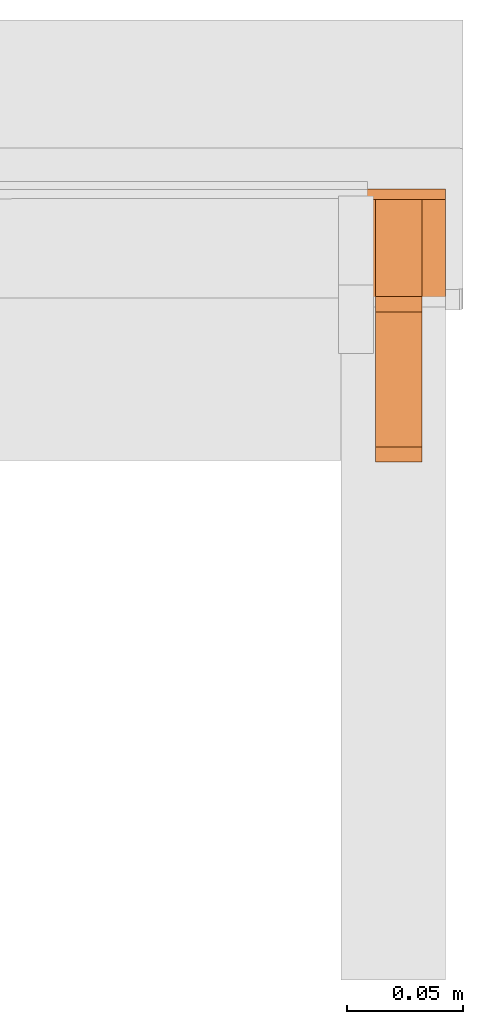
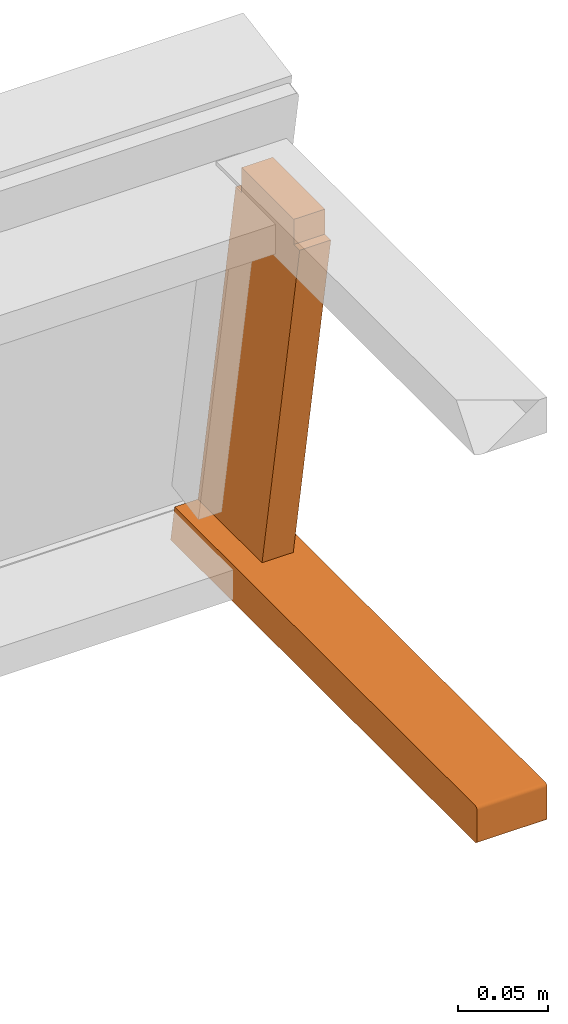
# One storey, part 4 of 5: 2 proxies, 1 element without a shape of its own.
"""IFC2X3 building model written with IfcOpenShell, lengths in metres."""

from ifc_helpers import new_model, si_unit, direction, origin_with_axes, place, context, project, spatial, faceted_brep, source, transform, mapped, element, aggregate, save


model = new_model("IFC2X3")

# Units and contexts
model_context = context("Model", 3, precision=1e-06, world=origin_with_axes(), true_north=direction((0.0, 1.0, 0.0)))
ifc_project = project(units=[si_unit("LENGTHUNIT", "METRE"), si_unit("AREAUNIT", "SQUARE_METRE"), si_unit("VOLUMEUNIT", "CUBIC_METRE")], contexts=[model_context])

# Site, building, storey
site_placement = place(None, origin_with_axes())
site = spatial("IfcSite", under=ifc_project, at=site_placement, CompositionType="ELEMENT")
building_placement = place(site_placement, origin_with_axes())
building = spatial("IfcBuilding", under=site, at=building_placement, Name="Default Building", CompositionType="ELEMENT")
storey_placement = place(building_placement, origin_with_axes())
storey = spatial("IfcBuildingStorey", under=building, at=storey_placement, Name="Default Storey", CompositionType="ELEMENT", Elevation=0.0)

# Assembly, proxies
assembly_placement = place(storey_placement, origin_with_axes())
assembly = element("IfcElementAssembly", 1, at=assembly_placement, inside=storey, Name="Pan H-68-037-A-REV reduced", ObjectType="Pan H-68-037-A-REV reduced", AssemblyPlace="NOTDEFINED", PredefinedType="NOTDEFINED")
shared_shape_1 = source(origin_with_axes(), model_context, "Body", "Brep", [
    faceted_brep([(0.2150000035762787, -0.08182960003614426, 0.24950098991394043), (0.2150000035762787, -0.07528966665267944, 0.24950098991394043), (0.19499999284744263, -0.08182960003614426, 0.24950098991394043), (0.19499999284744263, -0.08182960003614426, 0.24950098991394043), (0.2150000035762787, -0.07528966665267944, 0.24950098991394043), (0.19499999284744263, -0.07528966665267944, 0.24950098991394043), (0.2150000035762787, -0.07528966665267944, 0.24950098991394043), (0.2150000035762787, -0.07528966665267944, 0.26650097966194153), (0.19499999284744263, -0.07528966665267944, 0.24950098991394043), (0.19499999284744263, -0.07528966665267944, 0.24950098991394043), (0.2150000035762787, -0.07528966665267944, 0.26650097966194153), (0.19499999284744263, -0.07528966665267944, 0.26650097966194153), (0.2150000035762787, -0.07528966665267944, 0.26650097966194153), (0.2150000035762787, -0.07028967142105103, 0.26650097966194153), (0.19499999284744263, -0.07528966665267944, 0.26650097966194153), (0.19499999284744263, -0.07528966665267944, 0.26650097966194153), (0.2150000035762787, -0.07028967142105103, 0.26650097966194153), (0.19499999284744263, -0.07028967142105103, 0.26650097966194153), (0.2150000035762787, -0.07028967142105103, 0.26650097966194153), (0.2150000035762787, -0.022289669141173363, 0.26650097966194153), (0.19499999284744263, -0.07028967142105103, 0.26650097966194153), (0.19499999284744263, -0.07028967142105103, 0.26650097966194153), (0.2150000035762787, -0.022289669141173363, 0.26650097966194153), (0.19499999284744263, -0.022289669141173363, 0.26650097966194153), (0.2150000035762787, -0.022289669141173363, 0.26650097966194153), (0.2150000035762787, -0.017289668321609497, 0.26650097966194153), (0.19499999284744263, -0.022289669141173363, 0.26650097966194153), (0.19499999284744263, -0.022289669141173363, 0.26650097966194153), (0.2150000035762787, -0.017289668321609497, 0.26650097966194153), (0.19499999284744263, -0.017289668321609497, 0.26650097966194153), (0.2150000035762787, -0.017289668321609497, 0.26650097966194153), (0.2150000035762787, -0.017289668321609497, 0.24950098991394043), (0.19499999284744263, -0.017289668321609497, 0.26650097966194153), (0.19499999284744263, -0.017289668321609497, 0.26650097966194153), (0.2150000035762787, -0.017289668321609497, 0.24950098991394043), (0.19499999284744263, -0.017289668321609497, 0.24950098991394043), (0.2150000035762787, -0.017289668321609497, 0.24950098991394043), (0.2150000035762787, -0.010749737732112408, 0.24950098991394043), (0.19499999284744263, -0.017289668321609497, 0.24950098991394043), (0.19499999284744263, -0.017289668321609497, 0.24950098991394043), (0.2150000035762787, -0.010749737732112408, 0.24950098991394043), (0.19499999284744263, -0.010749737732112408, 0.24950098991394043), (0.2150000035762787, -0.010749737732112408, 0.24950098991394043), (0.2150000035762787, 0.031039930880069733, 0.012500000186264515), (0.19499999284744263, -0.010749737732112408, 0.24950098991394043), (0.19499999284744263, -0.010749737732112408, 0.24950098991394043), (0.2150000035762787, 0.031039930880069733, 0.012500000186264515), (0.19499999284744263, 0.031039930880069733, 0.012500000186264515), (0.2150000035762787, 0.031039930880069733, 0.012500000186264515), (0.2150000035762787, 0.02449999935925007, 0.012500000186264515), (0.19499999284744263, 0.031039930880069733, 0.012500000186264515), (0.19499999284744263, 0.031039930880069733, 0.012500000186264515), (0.2150000035762787, 0.02449999935925007, 0.012500000186264515), (0.19499999284744263, 0.02449999935925007, 0.012500000186264515), (0.2150000035762787, 0.02449999935925007, 0.012500000186264515), (0.2150000035762787, 0.02449999935925007, -0.0044999998062849045), (0.19499999284744263, 0.02449999935925007, 0.012500000186264515), (0.19499999284744263, 0.02449999935925007, 0.012500000186264515), (0.2150000035762787, 0.02449999935925007, -0.0044999998062849045), (0.19499999284744263, 0.02449999935925007, -0.0044999998062849045), (0.2150000035762787, 0.02449999935925007, -0.0044999998062849045), (0.2150000035762787, 0.019500000402331352, -0.0044999998062849045), (0.19499999284744263, 0.02449999935925007, -0.0044999998062849045), (0.19499999284744263, 0.02449999935925007, -0.0044999998062849045), (0.2150000035762787, 0.019500000402331352, -0.0044999998062849045), (0.19499999284744263, 0.019500000402331352, -0.0044999998062849045), (0.2150000035762787, 0.019500000402331352, -0.0044999998062849045), (0.2150000035762787, -0.02850000001490116, -0.0044999998062849045), (0.19499999284744263, 0.019500000402331352, -0.0044999998062849045), (0.19499999284744263, 0.019500000402331352, -0.0044999998062849045), (0.2150000035762787, -0.02850000001490116, -0.0044999998062849045), (0.19499999284744263, -0.02850000001490116, -0.0044999998062849045), (0.2150000035762787, -0.02850000001490116, -0.0044999998062849045), (0.2150000035762787, -0.03350000083446503, -0.0044999998062849045), (0.19499999284744263, -0.02850000001490116, -0.0044999998062849045), (0.19499999284744263, -0.02850000001490116, -0.0044999998062849045), (0.2150000035762787, -0.03350000083446503, -0.0044999998062849045), (0.19499999284744263, -0.03350000083446503, -0.0044999998062849045), (0.2150000035762787, -0.03350000083446503, -0.0044999998062849045), (0.2150000035762787, -0.03350000083446503, 0.012500000186264515), (0.19499999284744263, -0.03350000083446503, -0.0044999998062849045), (0.19499999284744263, -0.03350000083446503, -0.0044999998062849045), (0.2150000035762787, -0.03350000083446503, 0.012500000186264515), (0.19499999284744263, -0.03350000083446503, 0.012500000186264515), (0.2150000035762787, -0.03350000083446503, 0.012500000186264515), (0.2150000035762787, -0.04003993049263954, 0.012500000186264515), (0.19499999284744263, -0.03350000083446503, 0.012500000186264515), (0.19499999284744263, -0.03350000083446503, 0.012500000186264515), (0.2150000035762787, -0.04003993049263954, 0.012500000186264515), (0.19499999284744263, -0.04003993049263954, 0.012500000186264515), (0.2150000035762787, -0.04003993049263954, 0.012500000186264515), (0.2150000035762787, -0.08182960003614426, 0.24950098991394043), (0.19499999284744263, -0.04003993049263954, 0.012500000186264515), (0.19499999284744263, -0.04003993049263954, 0.012500000186264515), (0.2150000035762787, -0.08182960003614426, 0.24950098991394043), (0.19499999284744263, -0.08182960003614426, 0.24950098991394043), (0.2150000035762787, -0.07028967142105103, 0.26650097966194153), (0.2150000035762787, -0.07528966665267944, 0.26650097966194153), (0.2150000035762787, -0.07528966665267944, 0.24950098991394043), (0.2150000035762787, 0.02449999935925007, -0.0044999998062849045), (0.2150000035762787, 0.02449999935925007, 0.012500000186264515), (0.2150000035762787, 0.019500000402331352, -0.0044999998062849045), (0.2150000035762787, 0.019500000402331352, -0.0044999998062849045), (0.2150000035762787, 0.02449999935925007, 0.012500000186264515), (0.2150000035762787, -0.03350000083446503, 0.012500000186264515), (0.2150000035762787, 0.019500000402331352, -0.0044999998062849045), (0.2150000035762787, -0.03350000083446503, 0.012500000186264515), (0.2150000035762787, -0.02850000001490116, -0.0044999998062849045), (0.2150000035762787, -0.02850000001490116, -0.0044999998062849045), (0.2150000035762787, -0.03350000083446503, 0.012500000186264515), (0.2150000035762787, -0.03350000083446503, -0.0044999998062849045), (0.2150000035762787, -0.04003993049263954, 0.012500000186264515), (0.2150000035762787, -0.03350000083446503, 0.012500000186264515), (0.2150000035762787, -0.08182960003614426, 0.24950098991394043), (0.2150000035762787, -0.08182960003614426, 0.24950098991394043), (0.2150000035762787, -0.03350000083446503, 0.012500000186264515), (0.2150000035762787, 0.02449999935925007, 0.012500000186264515), (0.2150000035762787, -0.08182960003614426, 0.24950098991394043), (0.2150000035762787, 0.02449999935925007, 0.012500000186264515), (0.2150000035762787, -0.07528966665267944, 0.24950098991394043), (0.2150000035762787, -0.07528966665267944, 0.24950098991394043), (0.2150000035762787, 0.02449999935925007, 0.012500000186264515), (0.2150000035762787, 0.031039930880069733, 0.012500000186264515), (0.2150000035762787, -0.07528966665267944, 0.24950098991394043), (0.2150000035762787, 0.031039930880069733, 0.012500000186264515), (0.2150000035762787, -0.017289668321609497, 0.24950098991394043), (0.2150000035762787, -0.017289668321609497, 0.24950098991394043), (0.2150000035762787, 0.031039930880069733, 0.012500000186264515), (0.2150000035762787, -0.010749737732112408, 0.24950098991394043), (0.2150000035762787, -0.07028967142105103, 0.26650097966194153), (0.2150000035762787, -0.07528966665267944, 0.24950098991394043), (0.2150000035762787, -0.022289669141173363, 0.26650097966194153), (0.2150000035762787, -0.022289669141173363, 0.26650097966194153), (0.2150000035762787, -0.07528966665267944, 0.24950098991394043), (0.2150000035762787, -0.017289668321609497, 0.24950098991394043), (0.2150000035762787, -0.022289669141173363, 0.26650097966194153), (0.2150000035762787, -0.017289668321609497, 0.24950098991394043), (0.2150000035762787, -0.017289668321609497, 0.26650097966194153), (0.19499999284744263, -0.03350000083446503, 0.012500000186264515), (0.19499999284744263, -0.04003993049263954, 0.012500000186264515), (0.19499999284744263, -0.08182960003614426, 0.24950098991394043), (0.19499999284744263, -0.017289668321609497, 0.24950098991394043), (0.19499999284744263, -0.010749737732112408, 0.24950098991394043), (0.19499999284744263, 0.031039930880069733, 0.012500000186264515), (0.19499999284744263, -0.02850000001490116, -0.0044999998062849045), (0.19499999284744263, -0.03350000083446503, -0.0044999998062849045), (0.19499999284744263, -0.03350000083446503, 0.012500000186264515), (0.19499999284744263, -0.022289669141173363, 0.26650097966194153), (0.19499999284744263, -0.017289668321609497, 0.26650097966194153), (0.19499999284744263, -0.017289668321609497, 0.24950098991394043), (0.19499999284744263, -0.02850000001490116, -0.0044999998062849045), (0.19499999284744263, -0.03350000083446503, 0.012500000186264515), (0.19499999284744263, 0.019500000402331352, -0.0044999998062849045), (0.19499999284744263, 0.02449999935925007, 0.012500000186264515), (0.19499999284744263, 0.02449999935925007, -0.0044999998062849045), (0.19499999284744263, 0.019500000402331352, -0.0044999998062849045), (0.19499999284744263, -0.07528966665267944, 0.24950098991394043), (0.19499999284744263, -0.07528966665267944, 0.26650097966194153), (0.19499999284744263, -0.07028967142105103, 0.26650097966194153), (0.19499999284744263, 0.019500000402331352, -0.0044999998062849045), (0.19499999284744263, -0.03350000083446503, 0.012500000186264515), (0.19499999284744263, 0.02449999935925007, 0.012500000186264515), (0.19499999284744263, 0.02449999935925007, 0.012500000186264515), (0.19499999284744263, -0.03350000083446503, 0.012500000186264515), (0.19499999284744263, -0.08182960003614426, 0.24950098991394043), (0.19499999284744263, 0.02449999935925007, 0.012500000186264515), (0.19499999284744263, -0.08182960003614426, 0.24950098991394043), (0.19499999284744263, 0.031039930880069733, 0.012500000186264515), (0.19499999284744263, 0.031039930880069733, 0.012500000186264515), (0.19499999284744263, -0.08182960003614426, 0.24950098991394043), (0.19499999284744263, -0.07528966665267944, 0.24950098991394043), (0.19499999284744263, 0.031039930880069733, 0.012500000186264515), (0.19499999284744263, -0.07528966665267944, 0.24950098991394043), (0.19499999284744263, -0.017289668321609497, 0.24950098991394043), (0.19499999284744263, -0.017289668321609497, 0.24950098991394043), (0.19499999284744263, -0.07528966665267944, 0.24950098991394043), (0.19499999284744263, -0.07028967142105103, 0.26650097966194153), (0.19499999284744263, -0.017289668321609497, 0.24950098991394043), (0.19499999284744263, -0.07028967142105103, 0.26650097966194153), (0.19499999284744263, -0.022289669141173363, 0.26650097966194153)], [[[0, 1, 2]], [[3, 4, 5]], [[6, 7, 8]], [[9, 10, 11]], [[12, 13, 14]], [[15, 16, 17]], [[18, 19, 20]], [[21, 22, 23]], [[24, 25, 26]], [[27, 28, 29]], [[30, 31, 32]], [[33, 34, 35]], [[36, 37, 38]], [[39, 40, 41]], [[42, 43, 44]], [[45, 46, 47]], [[48, 49, 50]], [[51, 52, 53]], [[54, 55, 56]], [[57, 58, 59]], [[60, 61, 62]], [[63, 64, 65]], [[66, 67, 68]], [[69, 70, 71]], [[72, 73, 74]], [[75, 76, 77]], [[78, 79, 80]], [[81, 82, 83]], [[84, 85, 86]], [[87, 88, 89]], [[90, 91, 92]], [[93, 94, 95]], [[96, 97, 98]], [[99, 100, 101]], [[102, 103, 104]], [[105, 106, 107]], [[108, 109, 110]], [[111, 112, 113]], [[114, 115, 116]], [[117, 118, 119]], [[120, 121, 122]], [[123, 124, 125]], [[126, 127, 128]], [[129, 130, 131]], [[132, 133, 134]], [[135, 136, 137]], [[138, 139, 140]], [[141, 142, 143]], [[144, 145, 146]], [[147, 148, 149]], [[150, 151, 152]], [[153, 154, 155]], [[156, 157, 158]], [[159, 160, 161]], [[162, 163, 164]], [[165, 166, 167]], [[168, 169, 170]], [[171, 172, 173]], [[174, 175, 176]], [[177, 178, 179]]]),
])
proxy_1_placement = place(assembly_placement, origin_with_axes())
proxy_1 = element("IfcBuildingElementProxy", 2, at=proxy_1_placement, Name="24", ObjectType="24", CompositionType="ELEMENT", context=model_context, shape_type="MappedRepresentation", body=[
    mapped(shared_shape_1, transform((0.0, 0.0, 0.0), scale=1.0)),
])
shared_shape_2 = source(origin_with_axes(), model_context, "Body", "Brep", [
    faceted_brep([(0.22499999403953552, 0.031055916100740433, 0.012500000186264515), (0.22499999403953552, 0.03140857070684433, 0.010499999858438969), (0.18000000715255737, 0.031055916100740433, 0.012500000186264515), (0.18000000715255737, 0.031055916100740433, 0.012500000186264515), (0.22499999403953552, 0.03140857070684433, 0.010499999858438969), (0.18000000715255737, 0.03140857070684433, 0.010499999858438969), (0.22499999403953552, 0.03140857070684433, 0.010499999858438969), (0.22499999403953552, 0.0351114347577095, -0.010499999858438969), (0.18000000715255737, 0.03140857070684433, 0.010499999858438969), (0.18000000715255737, 0.03140857070684433, 0.010499999858438969), (0.22499999403953552, 0.0351114347577095, -0.010499999858438969), (0.18000000715255737, 0.0351114347577095, -0.010499999858438969), (0.22499999403953552, 0.0351114347577095, -0.010499999858438969), (0.22499999403953552, 0.0354640893638134, -0.012500000186264515), (0.18000000715255737, 0.0351114347577095, -0.010499999858438969), (0.18000000715255737, 0.0351114347577095, -0.010499999858438969), (0.22499999403953552, 0.0354640893638134, -0.012500000186264515), (0.18000000715255737, 0.0354640893638134, -0.012500000186264515), (0.22499999403953552, 0.0354640893638134, -0.012500000186264515), (0.22499999403953552, -0.04950062558054924, -0.012500000186264515), (0.18000000715255737, 0.0354640893638134, -0.012500000186264515), (0.18000000715255737, 0.0354640893638134, -0.012500000186264515), (0.22499999403953552, -0.04950062558054924, -0.012500000186264515), (0.18000000715255737, -0.04950062558054924, -0.012500000186264515), (0.22499999403953552, -0.04950062558054924, -0.012500000186264515), (0.22499999403953552, -0.30253592133522034, -0.012500000186264515), (0.18000000715255737, -0.04950062558054924, -0.012500000186264515), (0.18000000715255737, -0.04950062558054924, -0.012500000186264515), (0.22499999403953552, -0.30253592133522034, -0.012500000186264515), (0.18000000715255737, -0.30253592133522034, -0.012500000186264515), (0.22499999403953552, -0.3045358955860138, -0.010499999858438969), (0.18000000715255737, -0.3045358955860138, -0.010499999858438969), (0.18000000715255737, -0.3044677674770355, -0.011017638258635998), (0.22499999403953552, -0.3045358955860138, -0.010499999858438969), (0.18000000715255737, -0.3044677674770355, -0.011017638258635998), (0.22499999403953552, -0.3044677674770355, -0.011017638258635998), (0.22499999403953552, -0.3044677674770355, -0.011017638258635998), (0.18000000715255737, -0.3044677674770355, -0.011017638258635998), (0.18000000715255737, -0.3042679727077484, -0.011500000022351742), (0.22499999403953552, -0.3044677674770355, -0.011017638258635998), (0.18000000715255737, -0.3042679727077484, -0.011500000022351742), (0.22499999403953552, -0.3042679727077484, -0.011500000022351742), (0.22499999403953552, -0.3042679727077484, -0.011500000022351742), (0.18000000715255737, -0.3042679727077484, -0.011500000022351742), (0.18000000715255737, -0.30395013093948364, -0.011914213187992573), (0.22499999403953552, -0.3042679727077484, -0.011500000022351742), (0.18000000715255737, -0.30395013093948364, -0.011914213187992573), (0.22499999403953552, -0.30395013093948364, -0.011914213187992573), (0.22499999403953552, -0.30395013093948364, -0.011914213187992573), (0.18000000715255737, -0.30395013093948364, -0.011914213187992573), (0.18000000715255737, -0.30353590846061707, -0.012232051230967045), (0.22499999403953552, -0.30395013093948364, -0.011914213187992573), (0.18000000715255737, -0.30353590846061707, -0.012232051230967045), (0.22499999403953552, -0.30353590846061707, -0.012232051230967045), (0.22499999403953552, -0.30353590846061707, -0.012232051230967045), (0.18000000715255737, -0.30353590846061707, -0.012232051230967045), (0.18000000715255737, -0.3030535578727722, -0.012431851588189602), (0.22499999403953552, -0.30353590846061707, -0.012232051230967045), (0.18000000715255737, -0.3030535578727722, -0.012431851588189602), (0.22499999403953552, -0.3030535578727722, -0.012431851588189602), (0.22499999403953552, -0.3030535578727722, -0.012431851588189602), (0.18000000715255737, -0.3030535578727722, -0.012431851588189602), (0.18000000715255737, -0.30253592133522034, -0.012500000186264515), (0.22499999403953552, -0.3030535578727722, -0.012431851588189602), (0.18000000715255737, -0.30253592133522034, -0.012500000186264515), (0.22499999403953552, -0.30253592133522034, -0.012500000186264515), (0.22499999403953552, -0.3045358955860138, -0.010499999858438969), (0.22499999403953552, -0.3045358955860138, 0.010499999858438969), (0.18000000715255737, -0.3045358955860138, -0.010499999858438969), (0.18000000715255737, -0.3045358955860138, -0.010499999858438969), (0.22499999403953552, -0.3045358955860138, 0.010499999858438969), (0.18000000715255737, -0.3045358955860138, 0.010499999858438969), (0.22499999403953552, -0.30253592133522034, 0.012500000186264515), (0.18000000715255737, -0.30253592133522034, 0.012500000186264515), (0.18000000715255737, -0.3030535578727722, 0.012431851588189602), (0.22499999403953552, -0.30253592133522034, 0.012500000186264515), (0.18000000715255737, -0.3030535578727722, 0.012431851588189602), (0.22499999403953552, -0.3030535578727722, 0.012431851588189602), (0.22499999403953552, -0.3030535578727722, 0.012431851588189602), (0.18000000715255737, -0.3030535578727722, 0.012431851588189602), (0.18000000715255737, -0.30353590846061707, 0.012232051230967045), (0.22499999403953552, -0.3030535578727722, 0.012431851588189602), (0.18000000715255737, -0.30353590846061707, 0.012232051230967045), (0.22499999403953552, -0.30353590846061707, 0.012232051230967045), (0.22499999403953552, -0.30353590846061707, 0.012232051230967045), (0.18000000715255737, -0.30353590846061707, 0.012232051230967045), (0.18000000715255737, -0.30395013093948364, 0.011914213187992573), (0.22499999403953552, -0.30353590846061707, 0.012232051230967045), (0.18000000715255737, -0.30395013093948364, 0.011914213187992573), (0.22499999403953552, -0.30395013093948364, 0.011914213187992573), (0.22499999403953552, -0.30395013093948364, 0.011914213187992573), (0.18000000715255737, -0.30395013093948364, 0.011914213187992573), (0.18000000715255737, -0.3042679727077484, 0.011500000022351742), (0.22499999403953552, -0.30395013093948364, 0.011914213187992573), (0.18000000715255737, -0.3042679727077484, 0.011500000022351742), (0.22499999403953552, -0.3042679727077484, 0.011500000022351742), (0.22499999403953552, -0.3042679727077484, 0.011500000022351742), (0.18000000715255737, -0.3042679727077484, 0.011500000022351742), (0.18000000715255737, -0.3044677674770355, 0.011017638258635998), (0.22499999403953552, -0.3042679727077484, 0.011500000022351742), (0.18000000715255737, -0.3044677674770355, 0.011017638258635998), (0.22499999403953552, -0.3044677674770355, 0.011017638258635998), (0.22499999403953552, -0.3044677674770355, 0.011017638258635998), (0.18000000715255737, -0.3044677674770355, 0.011017638258635998), (0.18000000715255737, -0.3045358955860138, 0.010499999858438969), (0.22499999403953552, -0.3044677674770355, 0.011017638258635998), (0.18000000715255737, -0.3045358955860138, 0.010499999858438969), (0.22499999403953552, -0.3045358955860138, 0.010499999858438969), (0.22499999403953552, -0.30253592133522034, 0.012500000186264515), (0.22499999403953552, -0.04950062558054924, 0.012500000186264515), (0.18000000715255737, -0.30253592133522034, 0.012500000186264515), (0.18000000715255737, -0.30253592133522034, 0.012500000186264515), (0.22499999403953552, -0.04950062558054924, 0.012500000186264515), (0.18000000715255737, -0.04950062558054924, 0.012500000186264515), (0.22499999403953552, -0.04950062558054924, 0.012500000186264515), (0.22499999403953552, 0.031055916100740433, 0.012500000186264515), (0.18000000715255737, -0.04950062558054924, 0.012500000186264515), (0.18000000715255737, -0.04950062558054924, 0.012500000186264515), (0.22499999403953552, 0.031055916100740433, 0.012500000186264515), (0.18000000715255737, 0.031055916100740433, 0.012500000186264515), (0.22499999403953552, -0.30253592133522034, -0.012500000186264515), (0.22499999403953552, -0.04950062558054924, -0.012500000186264515), (0.22499999403953552, -0.04950062558054924, 0.012500000186264515), (0.22499999403953552, 0.031055916100740433, 0.012500000186264515), (0.22499999403953552, -0.04950062558054924, 0.012500000186264515), (0.22499999403953552, 0.03140857070684433, 0.010499999858438969), (0.22499999403953552, 0.03140857070684433, 0.010499999858438969), (0.22499999403953552, -0.04950062558054924, 0.012500000186264515), (0.22499999403953552, -0.04950062558054924, -0.012500000186264515), (0.22499999403953552, 0.03140857070684433, 0.010499999858438969), (0.22499999403953552, -0.04950062558054924, -0.012500000186264515), (0.22499999403953552, 0.0351114347577095, -0.010499999858438969), (0.22499999403953552, 0.0351114347577095, -0.010499999858438969), (0.22499999403953552, -0.04950062558054924, -0.012500000186264515), (0.22499999403953552, 0.0354640893638134, -0.012500000186264515), (0.22499999403953552, -0.3044677674770355, -0.011017638258635998), (0.22499999403953552, -0.3042679727077484, -0.011500000022351742), (0.22499999403953552, -0.30395013093948364, -0.011914213187992573), (0.22499999403953552, -0.3030535578727722, 0.012431851588189602), (0.22499999403953552, -0.30353590846061707, 0.012232051230967045), (0.22499999403953552, -0.3045358955860138, 0.010499999858438969), (0.22499999403953552, -0.3045358955860138, 0.010499999858438969), (0.22499999403953552, -0.30353590846061707, 0.012232051230967045), (0.22499999403953552, -0.30395013093948364, 0.011914213187992573), (0.22499999403953552, -0.3045358955860138, 0.010499999858438969), (0.22499999403953552, -0.30395013093948364, 0.011914213187992573), (0.22499999403953552, -0.3044677674770355, 0.011017638258635998), (0.22499999403953552, -0.3044677674770355, 0.011017638258635998), (0.22499999403953552, -0.30395013093948364, 0.011914213187992573), (0.22499999403953552, -0.3042679727077484, 0.011500000022351742), (0.22499999403953552, -0.3044677674770355, -0.011017638258635998), (0.22499999403953552, -0.30395013093948364, -0.011914213187992573), (0.22499999403953552, -0.3045358955860138, -0.010499999858438969), (0.22499999403953552, -0.3045358955860138, -0.010499999858438969), (0.22499999403953552, -0.30395013093948364, -0.011914213187992573), (0.22499999403953552, -0.30353590846061707, -0.012232051230967045), (0.22499999403953552, -0.3045358955860138, -0.010499999858438969), (0.22499999403953552, -0.30353590846061707, -0.012232051230967045), (0.22499999403953552, -0.3030535578727722, -0.012431851588189602), (0.22499999403953552, -0.3030535578727722, -0.012431851588189602), (0.22499999403953552, -0.30253592133522034, -0.012500000186264515), (0.22499999403953552, -0.3045358955860138, -0.010499999858438969), (0.22499999403953552, -0.3045358955860138, -0.010499999858438969), (0.22499999403953552, -0.30253592133522034, -0.012500000186264515), (0.22499999403953552, -0.04950062558054924, 0.012500000186264515), (0.22499999403953552, -0.3045358955860138, -0.010499999858438969), (0.22499999403953552, -0.04950062558054924, 0.012500000186264515), (0.22499999403953552, -0.3045358955860138, 0.010499999858438969), (0.22499999403953552, -0.3045358955860138, 0.010499999858438969), (0.22499999403953552, -0.04950062558054924, 0.012500000186264515), (0.22499999403953552, -0.30253592133522034, 0.012500000186264515), (0.22499999403953552, -0.3045358955860138, 0.010499999858438969), (0.22499999403953552, -0.30253592133522034, 0.012500000186264515), (0.22499999403953552, -0.3030535578727722, 0.012431851588189602), (0.18000000715255737, 0.0351114347577095, -0.010499999858438969), (0.18000000715255737, 0.0354640893638134, -0.012500000186264515), (0.18000000715255737, -0.04950062558054924, -0.012500000186264515), (0.18000000715255737, 0.0351114347577095, -0.010499999858438969), (0.18000000715255737, -0.04950062558054924, -0.012500000186264515), (0.18000000715255737, 0.03140857070684433, 0.010499999858438969), (0.18000000715255737, -0.3030535578727722, 0.012431851588189602), (0.18000000715255737, -0.30253592133522034, 0.012500000186264515), (0.18000000715255737, -0.3045358955860138, 0.010499999858438969), (0.18000000715255737, -0.3045358955860138, 0.010499999858438969), (0.18000000715255737, -0.30253592133522034, 0.012500000186264515), (0.18000000715255737, -0.04950062558054924, 0.012500000186264515), (0.18000000715255737, -0.3045358955860138, 0.010499999858438969), (0.18000000715255737, -0.04950062558054924, 0.012500000186264515), (0.18000000715255737, -0.3045358955860138, -0.010499999858438969), (0.18000000715255737, -0.3030535578727722, -0.012431851588189602), (0.18000000715255737, -0.30353590846061707, -0.012232051230967045), (0.18000000715255737, -0.3045358955860138, -0.010499999858438969), (0.18000000715255737, -0.3045358955860138, -0.010499999858438969), (0.18000000715255737, -0.30353590846061707, -0.012232051230967045), (0.18000000715255737, -0.30395013093948364, -0.011914213187992573), (0.18000000715255737, -0.3045358955860138, -0.010499999858438969), (0.18000000715255737, -0.30395013093948364, -0.011914213187992573), (0.18000000715255737, -0.3044677674770355, -0.011017638258635998), (0.18000000715255737, -0.3044677674770355, -0.011017638258635998), (0.18000000715255737, -0.30395013093948364, -0.011914213187992573), (0.18000000715255737, -0.3042679727077484, -0.011500000022351742), (0.18000000715255737, -0.3044677674770355, 0.011017638258635998), (0.18000000715255737, -0.3042679727077484, 0.011500000022351742), (0.18000000715255737, -0.30395013093948364, 0.011914213187992573), (0.18000000715255737, 0.031055916100740433, 0.012500000186264515), (0.18000000715255737, 0.03140857070684433, 0.010499999858438969), (0.18000000715255737, -0.04950062558054924, 0.012500000186264515), (0.18000000715255737, -0.04950062558054924, 0.012500000186264515), (0.18000000715255737, 0.03140857070684433, 0.010499999858438969), (0.18000000715255737, -0.04950062558054924, -0.012500000186264515), (0.18000000715255737, -0.04950062558054924, 0.012500000186264515), (0.18000000715255737, -0.04950062558054924, -0.012500000186264515), (0.18000000715255737, -0.3045358955860138, -0.010499999858438969), (0.18000000715255737, -0.3045358955860138, -0.010499999858438969), (0.18000000715255737, -0.04950062558054924, -0.012500000186264515), (0.18000000715255737, -0.30253592133522034, -0.012500000186264515), (0.18000000715255737, -0.3045358955860138, -0.010499999858438969), (0.18000000715255737, -0.30253592133522034, -0.012500000186264515), (0.18000000715255737, -0.3030535578727722, -0.012431851588189602), (0.18000000715255737, -0.3044677674770355, 0.011017638258635998), (0.18000000715255737, -0.30395013093948364, 0.011914213187992573), (0.18000000715255737, -0.3045358955860138, 0.010499999858438969), (0.18000000715255737, -0.3045358955860138, 0.010499999858438969), (0.18000000715255737, -0.30395013093948364, 0.011914213187992573), (0.18000000715255737, -0.30353590846061707, 0.012232051230967045), (0.18000000715255737, -0.3045358955860138, 0.010499999858438969), (0.18000000715255737, -0.30353590846061707, 0.012232051230967045), (0.18000000715255737, -0.3030535578727722, 0.012431851588189602)], [[[0, 1, 2]], [[3, 4, 5]], [[6, 7, 8]], [[9, 10, 11]], [[12, 13, 14]], [[15, 16, 17]], [[18, 19, 20]], [[21, 22, 23]], [[24, 25, 26]], [[27, 28, 29]], [[30, 31, 32]], [[33, 34, 35]], [[36, 37, 38]], [[39, 40, 41]], [[42, 43, 44]], [[45, 46, 47]], [[48, 49, 50]], [[51, 52, 53]], [[54, 55, 56]], [[57, 58, 59]], [[60, 61, 62]], [[63, 64, 65]], [[66, 67, 68]], [[69, 70, 71]], [[72, 73, 74]], [[75, 76, 77]], [[78, 79, 80]], [[81, 82, 83]], [[84, 85, 86]], [[87, 88, 89]], [[90, 91, 92]], [[93, 94, 95]], [[96, 97, 98]], [[99, 100, 101]], [[102, 103, 104]], [[105, 106, 107]], [[108, 109, 110]], [[111, 112, 113]], [[114, 115, 116]], [[117, 118, 119]], [[120, 121, 122]], [[123, 124, 125]], [[126, 127, 128]], [[129, 130, 131]], [[132, 133, 134]], [[135, 136, 137]], [[138, 139, 140]], [[141, 142, 143]], [[144, 145, 146]], [[147, 148, 149]], [[150, 151, 152]], [[153, 154, 155]], [[156, 157, 158]], [[159, 160, 161]], [[162, 163, 164]], [[165, 166, 167]], [[168, 169, 170]], [[171, 172, 173]], [[174, 175, 176]], [[177, 178, 179]], [[180, 181, 182]], [[183, 184, 185]], [[186, 187, 188]], [[189, 190, 191]], [[192, 193, 194]], [[195, 196, 197]], [[198, 199, 200]], [[201, 202, 203]], [[204, 205, 206]], [[207, 208, 209]], [[210, 211, 212]], [[213, 214, 215]], [[216, 217, 218]], [[219, 220, 221]], [[222, 223, 224]], [[225, 226, 227]]]),
])
proxy_2_placement = place(assembly_placement, origin_with_axes())
proxy_2 = element("IfcBuildingElementProxy", 3, at=proxy_2_placement, Name="25", ObjectType="25", CompositionType="ELEMENT", context=model_context, shape_type="MappedRepresentation", body=[
    mapped(shared_shape_2, transform((0.0, 0.0, 0.0), scale=1.0)),
])
aggregate(assembly, [proxy_1, proxy_2])

save(model, "model.ifc")
